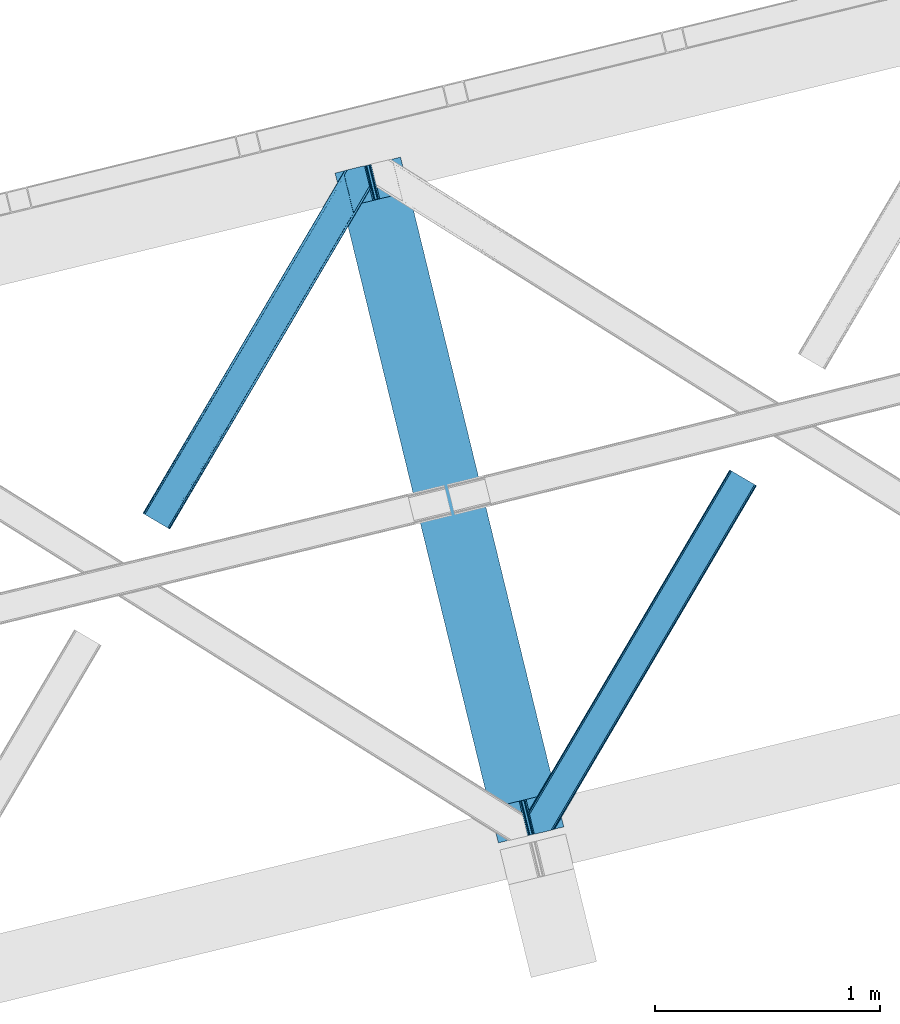
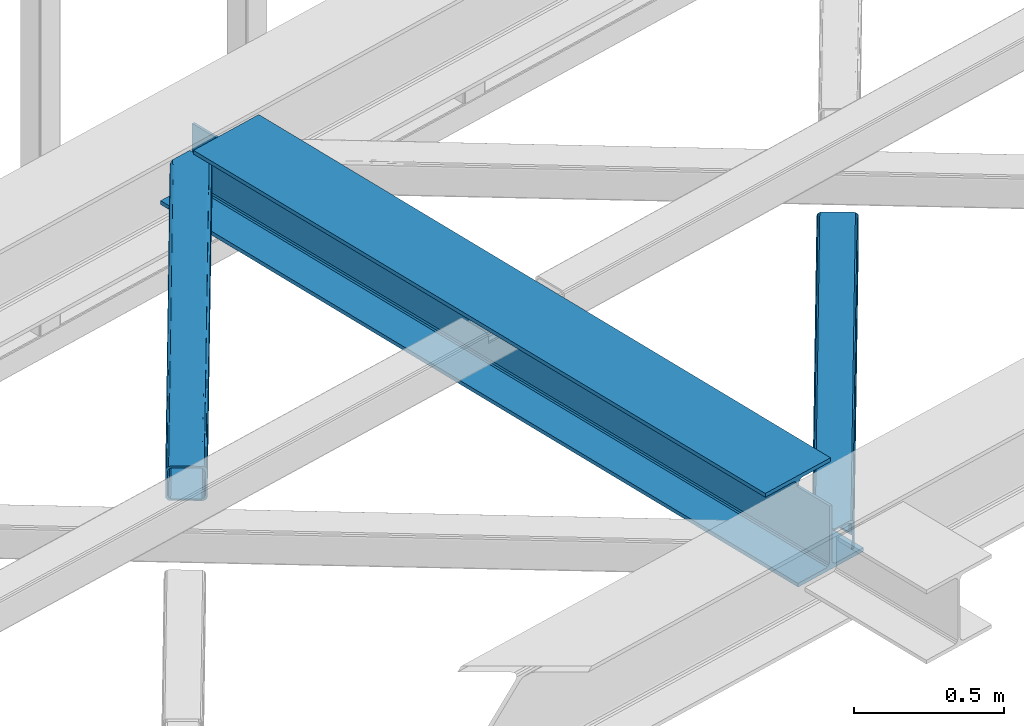
# One storey, part 21 of 66: 2 members, 1 beam.
"""IFC4 building model written with IfcOpenShell, lengths in millimetres."""

from ifc_helpers import new_model, entity, si_unit, converted_unit, derived_unit, direction, frame, origin, place, context, subcontext, project, spatial, triangles, polygons, material, type_object, element, save


model = new_model("IFC4")

# Units and contexts
model_context = context("Model", 3, precision=0.01, world=origin(), true_north=direction((6.12303176911189e-17, 1.0)))
plan_context = context("Plan", 3, precision=0.01, world=origin(), true_north=direction((6.12303176911189e-17, 1.0)))
body_context = subcontext(model_context, "Body", "Model", "MODEL_VIEW")
ifc_project = project(units=[si_unit("LENGTHUNIT", "METRE", prefix="MILLI"), si_unit("AREAUNIT", "SQUARE_METRE"), si_unit("VOLUMEUNIT", "CUBIC_METRE"), converted_unit("PLANEANGLEUNIT", "DEGREE", entity("IfcRatioMeasure", 0.0174532925199433), si_unit("PLANEANGLEUNIT", "RADIAN"), dimensions=[0, 0, 0, 0, 0, 0, 0]), si_unit("MASSUNIT", "GRAM", prefix="KILO"), derived_unit("MASSDENSITYUNIT", [(si_unit("MASSUNIT", "GRAM", prefix="KILO"), 1), (si_unit("LENGTHUNIT", "METRE"), -3)]), derived_unit("MOMENTOFINERTIAUNIT", [(si_unit("LENGTHUNIT", "METRE"), 4)]), si_unit("TIMEUNIT", "SECOND"), si_unit("FREQUENCYUNIT", "HERTZ"), si_unit("THERMODYNAMICTEMPERATUREUNIT", "DEGREE_CELSIUS"), derived_unit("THERMALTRANSMITTANCEUNIT", [(si_unit("MASSUNIT", "GRAM", prefix="KILO"), 1), (si_unit("THERMODYNAMICTEMPERATUREUNIT", "KELVIN"), -1), (si_unit("TIMEUNIT", "SECOND"), -3)]), derived_unit("VOLUMETRICFLOWRATEUNIT", [(si_unit("LENGTHUNIT", "METRE"), 3), (si_unit("TIMEUNIT", "SECOND"), -1)]), derived_unit("MASSFLOWRATEUNIT", [(si_unit("MASSUNIT", "GRAM", prefix="KILO"), 1), (si_unit("TIMEUNIT", "SECOND"), -1)]), derived_unit("ROTATIONALFREQUENCYUNIT", [(si_unit("TIMEUNIT", "SECOND"), -1)]), si_unit("ELECTRICCURRENTUNIT", "AMPERE"), si_unit("ELECTRICVOLTAGEUNIT", "VOLT"), si_unit("POWERUNIT", "WATT"), si_unit("FORCEUNIT", "NEWTON", prefix="KILO"), si_unit("ILLUMINANCEUNIT", "LUX"), si_unit("LUMINOUSFLUXUNIT", "LUMEN"), si_unit("LUMINOUSINTENSITYUNIT", "CANDELA"), derived_unit("USERDEFINED", [(si_unit("MASSUNIT", "GRAM", prefix="KILO"), -1), (si_unit("LENGTHUNIT", "METRE"), -2), (si_unit("TIMEUNIT", "SECOND"), 3), (si_unit("LUMINOUSFLUXUNIT", "LUMEN"), 1)]), derived_unit("LINEARVELOCITYUNIT", [(si_unit("LENGTHUNIT", "METRE"), 1), (si_unit("TIMEUNIT", "SECOND"), -1)]), si_unit("PRESSUREUNIT", "PASCAL"), derived_unit("USERDEFINED", [(si_unit("LENGTHUNIT", "METRE"), -2), (si_unit("MASSUNIT", "GRAM", prefix="KILO"), 1), (si_unit("TIMEUNIT", "SECOND"), -2)]), derived_unit("LINEARFORCEUNIT", [(si_unit("MASSUNIT", "GRAM", prefix="KILO"), 1), (si_unit("LENGTHUNIT", "METRE"), 1), (si_unit("TIMEUNIT", "SECOND"), -2), (si_unit("LENGTHUNIT", "METRE"), -1)]), derived_unit("PLANARFORCEUNIT", [(si_unit("MASSUNIT", "GRAM", prefix="KILO"), 1), (si_unit("LENGTHUNIT", "METRE"), 1), (si_unit("TIMEUNIT", "SECOND"), -2), (si_unit("LENGTHUNIT", "METRE"), -2)])], contexts=[model_context, plan_context])

# Site, building, storey
site_placement = place(None, origin())
site = spatial("IfcSite", under=ifc_project, at=site_placement, CompositionType="ELEMENT")
building_placement = place(site_placement, origin())
building = spatial("IfcBuilding", under=site, at=building_placement, CompositionType="ELEMENT")
storey_placement = place(building_placement, frame((0.0, 0.0, 19800.0)))
storey = spatial("IfcBuildingStorey", under=building, at=storey_placement, Name="06", CompositionType="ELEMENT", Elevation=19800.0)

# Beam
ifc_material = material(Name="Metal painted (White)")
beam_type = type_object("IfcBeamType", PredefinedType="BEAM")
beam_placement = place(storey_placement, frame((-55322.26, 4310.46, 3808.0)))
element("IfcBeam", 1, at=beam_placement, inside=storey, type_object=beam_type, material=ifc_material, ObjectType="Steel Beam", PredefinedType="BEAM", context=body_context, shape_type="Tessellation", body=[
    polygons([(1017.69283159732, 71.0478278971021, 15.5000000000051), (1017.69283159732, 71.0478278971021, 0.0), (291.465617442455, 3050.31221418793, 0.0), (291.465617442455, 3050.31221418793, 15.5000000000051), (894.305720213346, 40.9709140873291, 15.5000000000051), (168.078506058482, 3020.23530037816, 15.5000000000051), (887.613376439383, 39.3395844888243, 16.8701684148028), (161.386162284528, 3018.60397077965, 16.8701684148028), (881.939881338776, 37.9566100336519, 20.7720779386478), (155.712667183904, 3017.22099632448, 20.7720779386478), (878.148973110201, 37.0325360459184, 26.6116982174338), (151.921758955329, 3016.29692233675, 26.6116982174338), (876.817783166804, 36.7080444135029, 33.500000000001), (150.590569011932, 3015.97243070433, 33.500000000001), (140.875048430522, 3013.60416977443, 33.500000000001), (140.875048430522, 3013.60416977443, 259.000000000006), (150.590569011932, 3015.97243070433, 259.000000000006), (0.0, 2979.26438629083, 4.33146851719357e-12), (0.0, 2979.26438629083, 15.5000000000051), (123.387111383964, 3009.3413001006, 15.5000000000051), (130.079455157926, 3010.97262969911, 16.8701684148028), (135.752950258551, 3012.35560415428, 20.7720779386478), (139.543858487126, 3013.27967814201, 26.6116982174338), (876.817783166804, 36.7080444135029, 259.000000000006), (867.102262585394, 34.3397834835998, 259.000000000006), (867.102262585394, 34.3397834835998, 33.500000000001), (865.771072641989, 34.0152918511854, 26.6116982174338), (861.980164413414, 33.0912178634502, 20.7720779386478), (856.306669312798, 31.7082434082778, 16.8701684148028), (849.614325538844, 30.0769138097735, 15.5000000000051), (726.227214154872, 5.41433564649196e-13, 15.5000000000051), (726.22721415488, 0.0, 4.33146851719357e-12), (839.486273629598, 189.856409617334, 259.069792697269), (187.831472134673, 2863.19586956159, 259.000000000006), (188.054865236505, 2862.27942515662, 259.617303331129), (188.06725408013, 2862.22860092284, 266.500003008253), (839.341094842841, 190.451887551109, 266.500002998871), (839.341444963593, 190.450451246374, 260.000004007593), (829.861336398987, 187.116337424106, 259.006343170226), (829.637966360804, 188.032789031317, 259.617303331129), (829.625577517179, 188.08361326509, 266.500003008253), (178.351736754486, 2859.86032663682, 266.500002998871), (178.351386633734, 2859.86176294156, 260.000004007593), (178.20658097539, 2860.45581175535, 259.076120467494), (178.115951553254, 2860.82760863168, 259.000000000006), (840.672582712759, 190.775156995794, 273.388305639792), (844.462859301464, 191.701822167707, 279.227924098781), (850.135930248994, 193.086536631384, 283.129832400619), (856.828121930127, 194.718490162197, 284.500000377228), (980.21515061798, 224.795743217309, 284.500000138975), (980.213480811311, 224.802593286041, 299.999995328161), (688.748058714041, 153.753964021999, 299.999995890966), (688.749728520692, 153.747113953267, 284.500000701776), (812.136757208545, 183.824367008377, 284.500000463524), (818.829244104684, 185.455109474956, 283.129832461069), (824.503155753444, 186.836375119481, 279.227924137327), (828.294690540436, 187.757878768779, 273.388305663689), (177.020248884559, 2859.53705719214, 273.388305639792), (173.229972295863, 2858.61039202022, 279.227924098781), (167.556901348333, 2857.22567755655, 283.129832400619), (160.864709667199, 2855.59372402573, 284.500000377228), (37.4776809793468, 2825.51647097062, 284.500000138975), (37.4793507860071, 2825.50962090189, 299.999995328161), (328.944772883286, 2896.55825016593, 299.999995890962), (328.943103076634, 2896.56510023467, 284.500000701776), (205.556074388782, 2866.48784717955, 284.500000463524), (198.863587492643, 2864.85710471298, 283.129832461069), (193.189675843874, 2863.47583906845, 279.227924137327), (189.398141056891, 2862.55433541915, 273.388305663689)], [[[1, 2, 3, 4]], [[5, 1, 4, 6]], [[7, 5, 6, 8]], [[9, 7, 8, 10]], [[11, 9, 10, 12]], [[13, 11, 12, 14]], [[15, 16, 17, 14, 12, 10, 8, 6, 4, 3, 18, 19, 20, 21, 22, 23]], [[13, 24, 25, 26, 27, 28, 29, 30, 31, 32, 2, 1, 5, 7, 9, 11]], [[2, 32, 18, 3]], [[32, 31, 19, 18]], [[31, 30, 20, 19]], [[27, 26, 15, 23]], [[28, 27, 23, 22]], [[29, 28, 22, 21]], [[30, 29, 21, 20]], [[33, 24, 13, 14, 17, 34, 35, 36, 37, 38]], [[25, 39, 40, 41, 42, 43, 44, 16, 15, 26]], [[39, 25, 24, 33]], [[45, 34, 17, 16]], [[41, 40, 38, 37, 46, 47, 48, 49, 50, 51, 52, 53, 54, 55, 56, 57]], [[42, 58, 59, 60, 61, 62, 63, 64, 65, 66, 67, 68, 69, 36, 35, 43]], [[46, 37, 36, 69]], [[47, 46, 69, 68]], [[48, 47, 68, 67]], [[49, 48, 67, 66]], [[50, 49, 66, 65]], [[51, 50, 65, 64]], [[52, 51, 64, 63]], [[53, 52, 63, 62]], [[54, 53, 62, 61]], [[55, 54, 61, 60]], [[56, 55, 60, 59]], [[57, 56, 59, 58]], [[41, 57, 58, 42]]], closed=False),
])

# Members
member_type_1 = type_object("IfcMemberType", PredefinedType="BRACE")
member_1_placement = place(storey_placement, frame((-56177.58, 5705.47, 3824.0)))
element("IfcMember", 2, at=member_1_placement, inside=storey, type_object=member_type_1, ObjectType="Steel Horizontal Brace", PredefinedType="BRACE", context=body_context, shape_type="Tessellation", body=[
    triangles([(105.560998535155, 8.87794647216833, 0.0), (15.078149414061, 62.148532104492, 0.0), (892.843176269533, 1346.13992614746, 0.0), (857.166284179686, 1492.50250396729, 0.0), (854.892004394533, 1501.83739929199, 1.33247680664135), (9.30640869140916, 65.5459991455082, 1.33247680664135), (852.961889648439, 1509.75145111084, 5.12526855468968), (4.41368408202834, 68.4266372680668, 5.12526855468968), (851.673596191409, 1515.03950042725, 10.8039916992202), (1.14411621094041, 70.3509384155277, 10.8039916992202), (851.222460937497, 1516.89636383057, 17.5012573242202), (0.0, 71.0270599365231, 17.5012573242202), (893.633825683595, 1342.89768218994, 0.155804443358647), (111.332739257814, 5.48047943115216, 1.33247680664135), (899.559045410155, 1344.34178009033, 1.33247680664135), (912.390820312503, 1347.46949615478, 10.8039916992202), (914.195361328122, 1347.90958557129, 17.5012573242202), (120.643798828125, 0.0, 17.5012573242202), (119.495031738283, 0.675540161132631, 10.8039916992202), (907.251599121097, 1346.21666564941, 5.12526855468968), (116.225463867188, 2.60042266845721, 5.12526855468968), (902.493750000001, 1345.05743408203, 17.9802978515618), (893.633825683595, 1342.89768218994, 9.69243164062573), (897.763806152347, 1343.90459747314, 12.1248413085959), (903.721582031249, 1345.35683441162, 19.5011352539077), (914.195361328122, 1347.90958557129, 19.5011352539077), (1011.61732177735, 1513.38669433594, 19.5011352539077), (1008.98957519532, 1524.16103668213, 19.5011352539077), (1011.61732177735, 1513.38669433594, 122.499499511719), (120.643798828125, 0.0, 122.499499511719), (114.61160888672, 3.55094604492206, 24.5008300781265), (1009.23607177734, 1523.14423828125, 24.5008300781265), (113.462841796878, 4.22706756591833, 17.8035644531265), (110.193273925783, 6.15136871337927, 12.1248413085959), (105.300549316409, 9.03200683593786, 8.3320495605476), (99.52880859375, 12.4294738769531, 6.99957275390625), (892.685046386716, 1346.79976959229, 8.8831787109375), (890.466577148436, 1355.89747009277, 6.99957275390625), (21.1103393554658, 58.5970046997072, 6.99957275390625), (859.547534179685, 1482.74496002197, 6.99957275390625), (853.961828613283, 1505.66042175293, 18.501196289064), (851.222460937497, 1516.89636383057, 18.501196289064), (854.092053222659, 1505.10871124268, 17.8803039550803), (855.338488769528, 1499.99390716553, 12.1248413085959), (857.268603515622, 1492.07985534668, 8.3320495605476), (1009.23607177734, 1523.14423828125, 115.499926757813), (114.61160888672, 3.55094604492206, 115.499926757813), (1008.78493652344, 1525.00110168457, 122.197192382813), (113.462841796878, 4.22706756591833, 122.197192382813), (1007.49664306641, 1530.28856964111, 127.873590087893), (110.193273925783, 6.15136871337927, 127.873590087893), (1005.56652832031, 1538.20262145996, 131.668707275392), (105.300549316409, 9.03200683593786, 131.668707275392), (1003.29224853516, 1547.53809814453, 133.001184082033), (99.52880859375, 12.4294738769531, 133.001184082033), (851.947998046875, 1518.13291625977, 19.5011352539077), (854.575744628906, 1507.35857391357, 19.5011352539077), (851.775915527345, 1517.83991088867, 19.2639404296897), (854.426916503908, 1506.95045928955, 19.2592895507805), (851.585229492186, 1517.51434936523, 19.0011657714858), (854.268786621091, 1506.50920715332, 19.0011657714858), (851.394543457034, 1517.1887878418, 18.7360656738274), (854.106005859372, 1506.06795501709, 18.7407165527366), (908.014343261719, 1598.12628936768, 19.5011352539077), (897.540563964845, 1595.57353820801, 19.5011352539077), (1011.16153564453, 1515.24355773926, 129.196765136719), (1009.8732421875, 1520.53160705566, 134.87548828125), (1008.43146972657, 1526.45624542236, 138.000878906252), (986.307238769528, 1617.21117095947, 138.000878906252), (986.307238769528, 1617.21117095947, 133.001184082033), (897.540563964845, 1595.57353820801, 122.499499511719), (0.0, 71.0270599365231, 122.499499511719), (7.17630615234521, 66.799411010742, 17.8035644531265), (10.4458740234404, 64.8751098632811, 12.1248413085959), (6.03218994140479, 67.4755325317383, 24.5008300781265), (907.023706054686, 1597.88560638428, 24.5008300781265), (15.338598632814, 61.9944717407225, 8.3320495605476), (908.828247070313, 1598.32511444092, 122.197192382813), (899.345104980472, 1596.01362762451, 129.196765136719), (904.484326171878, 1597.26645812988, 134.87548828125), (930.73388671875, 1603.66490478516, 133.001184082033), (910.24211425781, 1598.66986083984, 138.000878906252), (921.660021972653, 1601.45341186523, 131.668707275392), (913.967468261719, 1599.57852630615, 127.873590087893), (907.023706054686, 1597.88560638428, 115.499926757813), (21.1103393554658, 58.5970046997072, 133.001184082033), (6.03218994140479, 67.4755325317383, 115.499926757813), (15.338598632814, 61.9944717407225, 131.668707275392), (10.4458740234404, 64.8751098632811, 127.873590087893), (7.17630615234521, 66.799411010742, 122.197192382813), (119.495031738283, 0.675540161132631, 129.196765136719), (116.225463867188, 2.60042266845721, 134.87548828125), (111.332739257814, 5.48047943115216, 138.668280029298), (105.560998535155, 8.87794647216833, 140.00075683594), (15.078149414061, 62.148532104492, 140.00075683594), (9.30640869140916, 65.5459991455082, 138.668280029298), (4.41368408202834, 68.4266372680668, 134.87548828125), (1.14411621094041, 70.3509384155277, 129.196765136719), (896.987109374997, 1576.15553741455, 138.000878906252), (938.18924560547, 1407.14434204102, 138.000878906252), (899.019543457034, 1563.59525756836, 140.00075683594), (897.038269042969, 1571.72266845703, 139.000817871096), (896.796423339845, 1573.13653564453, 138.638049316407), (896.926647949222, 1575.15443572998, 138.212493896484), (896.86153564453, 1574.14112548828, 138.426434326171), (937.473010253903, 1407.08562469482, 138.293884277344), (937.077685546872, 1408.09486541748, 138.647351074218), (936.682360839841, 1409.10410614014, 139.000817871096), (934.701086425783, 1417.23267974853, 140.00075683594)], [[1, 2, 3], [4, 3, 2], [5, 4, 6], [2, 6, 4], [7, 5, 8], [6, 8, 5], [9, 7, 10], [8, 10, 7], [11, 9, 12], [10, 12, 9], [1, 3, 13], [13, 14, 1], [13, 15, 14], [16, 17, 18], [18, 19, 16], [20, 16, 19], [19, 21, 20], [15, 20, 21], [21, 14, 15], [20, 22, 16], [23, 24, 15], [23, 15, 13], [15, 24, 20], [16, 25, 17], [20, 24, 22], [16, 22, 25], [26, 17, 25], [26, 25, 27], [28, 27, 25], [27, 29, 26], [30, 26, 29], [26, 18, 17], [30, 18, 26], [31, 32, 25], [25, 33, 31], [25, 22, 33], [32, 28, 25], [33, 22, 24], [34, 24, 23], [23, 35, 34], [36, 35, 37], [37, 38, 36], [23, 37, 35], [24, 34, 33], [39, 36, 38], [38, 40, 39], [9, 11, 41], [11, 42, 41], [43, 9, 41], [43, 7, 9], [44, 7, 43], [5, 44, 45], [44, 5, 7], [4, 5, 45], [45, 40, 4], [37, 23, 13], [37, 3, 38], [3, 40, 38], [40, 3, 4], [37, 13, 3], [46, 32, 31], [31, 47, 46], [48, 46, 49], [47, 49, 46], [50, 48, 51], [49, 51, 48], [52, 50, 53], [51, 53, 50], [54, 52, 55], [53, 55, 52], [56, 57, 58], [59, 58, 57], [58, 59, 60], [61, 60, 59], [60, 61, 62], [63, 62, 61], [62, 63, 42], [41, 42, 63], [57, 56, 64], [65, 64, 56], [66, 48, 67], [46, 29, 27], [27, 32, 46], [32, 27, 28], [48, 29, 46], [66, 29, 48], [50, 68, 67], [52, 68, 50], [67, 48, 50], [52, 54, 68], [54, 69, 68], [70, 69, 54], [71, 60, 62], [58, 60, 71], [71, 56, 58], [56, 71, 65], [42, 12, 72], [12, 42, 11], [71, 42, 72], [42, 71, 62], [73, 74, 44], [75, 73, 43], [43, 41, 75], [43, 57, 75], [64, 76, 57], [75, 57, 76], [44, 43, 73], [45, 44, 74], [74, 77, 45], [40, 45, 77], [77, 39, 40], [78, 79, 80], [81, 82, 69], [69, 70, 81], [81, 83, 82], [84, 82, 83], [80, 82, 84], [78, 71, 79], [85, 71, 78], [80, 84, 78], [65, 76, 64], [85, 65, 71], [76, 65, 85], [86, 54, 55], [54, 86, 81], [70, 54, 81], [76, 85, 87], [87, 75, 76], [83, 81, 86], [86, 88, 83], [84, 83, 88], [88, 89, 84], [78, 84, 89], [89, 90, 78], [85, 78, 90], [90, 87, 85], [91, 51, 49], [47, 18, 30], [91, 49, 30], [91, 92, 51], [49, 47, 30], [51, 92, 93], [55, 94, 95], [94, 53, 93], [53, 94, 55], [53, 51, 93], [19, 34, 21], [31, 18, 47], [18, 33, 19], [33, 18, 31], [19, 33, 34], [1, 36, 2], [14, 21, 34], [34, 35, 14], [35, 36, 1], [1, 14, 35], [89, 96, 97], [95, 86, 55], [95, 88, 86], [88, 95, 96], [89, 88, 96], [87, 72, 12], [98, 90, 89], [97, 98, 89], [90, 98, 72], [87, 90, 72], [6, 74, 8], [2, 36, 39], [39, 77, 2], [77, 74, 6], [6, 2, 77], [10, 8, 74], [12, 75, 87], [73, 12, 10], [12, 73, 75], [73, 10, 74], [99, 68, 82], [99, 100, 68], [68, 69, 82], [96, 95, 101], [101, 102, 96], [97, 96, 103], [104, 97, 105], [104, 99, 97], [97, 103, 105], [82, 80, 99], [97, 99, 80], [102, 103, 96], [79, 71, 98], [72, 98, 71], [80, 79, 97], [98, 97, 79], [92, 67, 100], [100, 93, 92], [67, 68, 100], [106, 107, 93], [94, 93, 107], [107, 108, 94], [108, 109, 94], [66, 67, 92], [92, 91, 66], [29, 66, 91], [91, 30, 29], [95, 94, 109], [109, 101, 95], [107, 103, 102], [105, 103, 107], [106, 104, 105], [100, 99, 104], [107, 106, 105], [102, 108, 107], [102, 101, 109], [109, 108, 102]]),
])
member_type_2 = type_object("IfcMemberType", PredefinedType="BRACE")
member_2_placement = place(storey_placement, frame((-54460.74, 4348.58, 3824.0)))
element("IfcMember", 3, at=member_2_placement, inside=storey, type_object=member_type_2, ObjectType="Steel Horizontal Brace", PredefinedType="BRACE", context=body_context, shape_type="Tessellation", body=[
    triangles([(154.451037597661, 124.708957672119, 0.0), (118.774145507814, 271.071535491944, 0.0), (998.971582031256, 1559.19901428223, 0.0), (908.488732910162, 1612.46901855469, 0.0), (1004.74332275391, 1555.80096588135, 1.33247680664135), (156.725317382814, 115.37377166748, 1.33247680664135), (1009.63604736328, 1552.92090911865, 5.12526855468968), (158.655432128908, 107.459719848634, 5.12526855468968), (1012.90561523438, 1550.99602661133, 10.8039916992202), (159.943725585938, 102.171961212159, 10.8039916992202), (1014.05438232422, 1550.3204864502, 17.5012573242202), (160.39486083985, 100.315097808838, 17.5012573242202), (902.716992187503, 1615.8664855957, 1.33247680664135), (116.495214843751, 280.406721496583, 1.33247680664135), (114.579052734378, 288.275717926026, 5.1694519042976), (897.824267578129, 1618.74712371826, 5.12526855468968), (114.499987792973, 288.596628570557, 5.32758178711083), (894.554699707034, 1620.67142486572, 10.8039916992202), (109.630517578131, 287.409491729737, 10.8039916992202), (893.410583496094, 1621.34754638672, 17.5012573242202), (107.825976562504, 286.969402313232, 17.5012573242202), (113.527954101563, 288.360015106202, 18.5197998046897), (114.499987792973, 288.596628570557, 17.5198608398459), (114.42557373047, 288.578606414795, 17.9035583496116), (114.216284179689, 288.527446746826, 18.2267944335945), (113.900024414063, 288.450416564941, 18.4453857421868), (107.825976562504, 286.969402313232, 18.5197998046897), (115.695263671878, 283.683847045899, 17.5198608398459), (115.625500488284, 283.800700378419, 17.8035644531265), (115.569689941411, 283.740529632569, 17.8570495605491), (115.323193359378, 283.495777130127, 18.0779663085959), (115.067395019534, 283.23939743042, 18.3081848144539), (114.834851074222, 283.003365325928, 18.5197998046897), (0.0, 103.824767303468, 18.5197998046897), (2.73936767578562, 92.5989990234375, 18.5197998046897), (893.410583496094, 1621.34754638672, 122.499499511719), (0.0, 103.824767303468, 122.499499511719), (908.488732910162, 1612.46901855469, 140.00075683594), (902.716992187503, 1615.8664855957, 138.668280029298), (3.6741943359375, 88.7660934448249, 138.668280029298), (5.94847412109812, 79.4309074401863, 140.00075683594), (897.824267578129, 1618.74712371826, 134.87548828125), (1.74407958984375, 96.6801452636719, 134.87548828125), (894.554699707034, 1620.67142486572, 129.196765136719), (0.455786132813955, 101.967903900147, 129.196765136719), (899.442773437506, 1617.79601898193, 24.5008300781265), (2.38125000000582, 94.0672233581545, 24.5008300781265), (900.591540527348, 1617.1204788208, 17.8035644531265), (903.856457519534, 1615.19559631348, 12.1248413085959), (914.520922851567, 1608.9174911499, 6.99957275390625), (908.749182128908, 1612.31553955078, 8.3320495605476), (118.87646484375, 270.64917755127, 8.3320495605476), (121.150744628911, 261.313991546631, 6.99957275390625), (116.946350097656, 278.563229370117, 12.1248413085959), (152.069787597662, 134.466501617432, 6.99957275390625), (992.939392089844, 1562.74996032715, 6.99957275390625), (156.274182128909, 117.217263793946, 12.1248413085959), (154.344067382815, 125.131315612794, 8.3320495605476), (157.525268554688, 112.096936798096, 17.5198608398459), (160.39486083985, 100.315097808838, 17.5198608398459), (899.442773437506, 1617.79601898193, 115.499926757813), (2.38125000000582, 94.0672233581545, 115.499926757813), (900.591540527348, 1617.1204788208, 122.197192382813), (2.83238525391062, 92.2103599548345, 122.197192382813), (903.856457519534, 1615.19559631348, 127.873590087893), (4.12067871094041, 86.9226013183597, 127.873590087893), (908.749182128908, 1612.31553955078, 131.668707275392), (6.05079345703416, 79.0085494995119, 131.668707275392), (914.520922851567, 1608.9174911499, 133.001184082033), (8.3250732421875, 69.6736541748051, 133.001184082033), (25.3100830078183, 0.0, 133.001184082033), (25.3100830078183, 0.0, 140.00075683594), (90.3665771484375, 15.8583343505861, 140.00075683594), (998.971582031256, 1559.19901428223, 140.00075683594), (1014.05438232422, 1550.3204864502, 122.499499511719), (1012.90561523438, 1550.99602661133, 129.196765136719), (114.076757812501, 21.6379234313972, 122.499499511719), (112.272216796875, 21.1978340148926, 129.196765136719), (1009.63604736328, 1552.92090911865, 134.87548828125), (107.132995605469, 19.9450035095215, 134.87548828125), (1004.74332275391, 1555.80096588135, 138.668280029298), (99.4404418945342, 18.0698272705085, 138.668280029298), (159.669323730472, 99.0785453796389, 18.5197998046897), (114.076757812501, 21.6379234313972, 18.5197998046897), (103.165795898443, 18.9782020568855, 18.5197998046897), (156.929956054693, 110.3046043396, 18.5197998046897), (1008.02219238281, 1553.87201385498, 24.5008300781265), (1006.87342529297, 1554.54755401611, 17.8035644531265), (157.22761230469, 111.200770568848, 18.0198303222678), (1003.60385742188, 1556.47243652344, 12.1248413085959), (998.711132812503, 1559.35249328613, 8.3320495605476), (104.593615722661, 19.3261459350588, 24.5008300781265), (1003.60385742188, 1556.47243652344, 127.873590087893), (1008.02219238281, 1553.87201385498, 115.499926757813), (1006.87342529297, 1554.54755401611, 122.197192382813), (992.939392089844, 1562.74996032715, 133.001184082033), (998.711132812503, 1559.35249328613, 131.668707275392), (102.789074707034, 18.8860565185551, 122.197192382813), (80.8834350585967, 13.5465568542486, 133.001184082033), (89.9572998046933, 15.7580497741701, 131.668707275392), (97.6498535156279, 17.633226013184, 127.873590087893), (104.593615722661, 19.3261459350588, 115.499926757813)], [[1, 2, 3], [4, 3, 2], [3, 5, 1], [6, 1, 5], [5, 7, 6], [8, 6, 7], [7, 9, 8], [10, 8, 9], [9, 11, 10], [12, 10, 11], [13, 14, 15], [16, 15, 17], [17, 18, 16], [17, 19, 18], [20, 18, 19], [19, 21, 20], [15, 16, 13], [13, 4, 14], [2, 14, 4], [22, 23, 24], [22, 25, 26], [27, 21, 22], [24, 25, 22], [23, 22, 21], [21, 19, 23], [17, 23, 19], [23, 28, 29], [29, 24, 23], [25, 24, 30], [26, 25, 31], [22, 26, 32], [32, 33, 22], [31, 32, 26], [30, 31, 25], [29, 30, 24], [34, 33, 35], [33, 34, 27], [22, 33, 27], [27, 20, 21], [36, 27, 37], [27, 36, 20], [27, 34, 37], [38, 39, 40], [40, 41, 38], [39, 42, 43], [43, 40, 39], [42, 44, 45], [45, 43, 42], [44, 36, 37], [37, 45, 44], [46, 47, 33], [33, 48, 46], [33, 31, 48], [47, 35, 33], [49, 48, 28], [50, 51, 52], [52, 53, 50], [51, 49, 54], [54, 52, 51], [28, 54, 49], [53, 55, 56], [56, 50, 53], [55, 2, 1], [54, 17, 14], [52, 14, 2], [52, 2, 53], [55, 53, 2], [17, 28, 23], [54, 28, 17], [52, 54, 14], [57, 58, 6], [58, 1, 6], [1, 58, 55], [8, 57, 6], [8, 59, 57], [10, 59, 8], [10, 60, 59], [46, 61, 47], [62, 47, 61], [61, 63, 62], [64, 62, 63], [63, 65, 64], [66, 64, 65], [65, 67, 66], [68, 66, 67], [67, 69, 68], [70, 68, 69], [66, 43, 64], [71, 72, 70], [72, 41, 70], [40, 68, 41], [66, 68, 40], [68, 70, 41], [66, 40, 43], [37, 34, 62], [45, 64, 43], [62, 64, 37], [64, 45, 37], [34, 47, 62], [34, 35, 47], [41, 73, 74], [73, 41, 72], [74, 38, 41], [75, 76, 77], [78, 77, 76], [76, 79, 78], [80, 78, 79], [79, 81, 80], [82, 80, 81], [81, 74, 82], [73, 82, 74], [60, 75, 77], [60, 11, 75], [77, 83, 60], [77, 84, 83], [84, 85, 83], [86, 83, 85], [87, 88, 59], [89, 86, 87], [88, 90, 57], [57, 59, 88], [90, 91, 58], [58, 57, 90], [91, 56, 55], [55, 58, 91], [87, 86, 92], [85, 92, 86], [9, 90, 88], [87, 75, 11], [9, 88, 11], [9, 7, 90], [88, 87, 11], [90, 7, 5], [56, 3, 4], [3, 91, 5], [91, 3, 56], [91, 90, 5], [76, 93, 79], [94, 75, 87], [75, 95, 76], [95, 75, 94], [76, 95, 93], [74, 96, 38], [81, 79, 93], [93, 97, 81], [97, 96, 74], [74, 81, 97], [49, 13, 16], [4, 50, 56], [4, 51, 50], [51, 4, 13], [49, 51, 13], [46, 20, 36], [18, 48, 49], [16, 18, 49], [48, 18, 20], [46, 48, 20], [39, 65, 42], [38, 96, 69], [69, 67, 38], [67, 65, 39], [39, 38, 67], [44, 42, 65], [36, 61, 46], [63, 36, 44], [36, 63, 61], [63, 44, 65], [98, 78, 80], [99, 73, 72], [72, 71, 99], [99, 100, 73], [100, 82, 73], [101, 82, 100], [80, 82, 101], [98, 77, 78], [102, 77, 98], [80, 101, 98], [84, 92, 85], [102, 84, 77], [92, 84, 102], [99, 70, 96], [99, 71, 70], [69, 96, 70], [96, 97, 100], [100, 99, 96], [97, 93, 101], [101, 100, 97], [93, 95, 98], [98, 101, 93], [95, 94, 102], [102, 98, 95], [94, 87, 102], [92, 102, 87]]),
])

save(model, "model.ifc")
